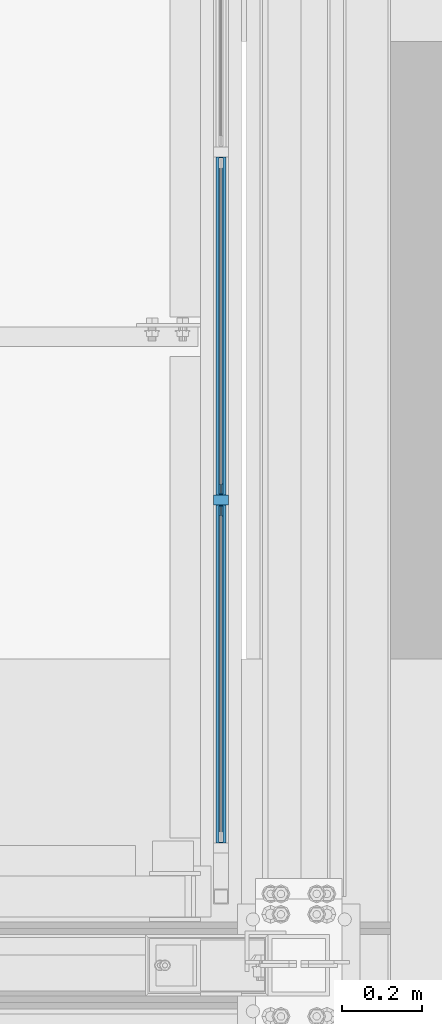
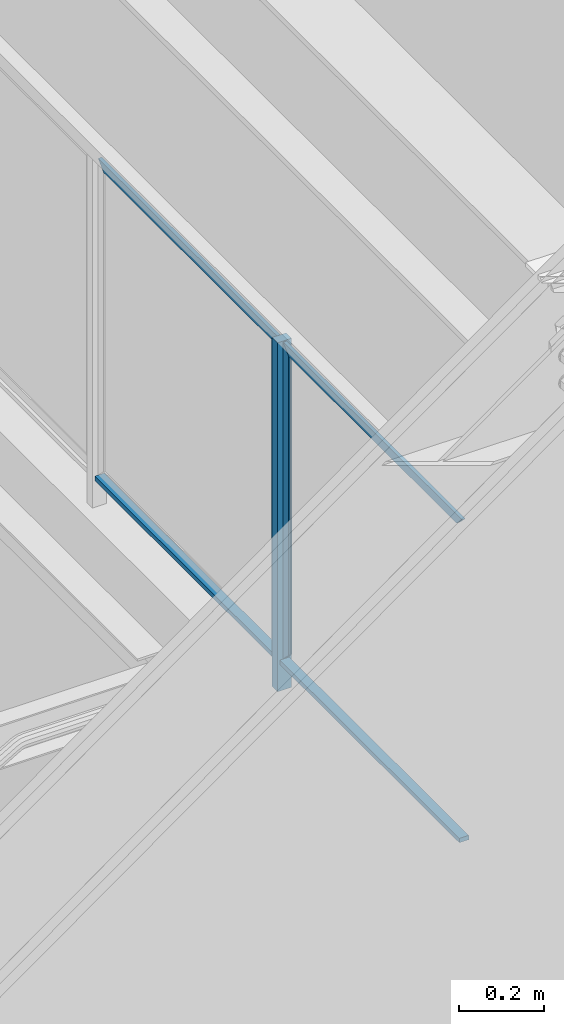
# One storey, part 923 of 1179: 4 beams, 3 members, 1 element without a shape of its own.
"""IFC2X3 building model written with IfcOpenShell, lengths in millimetres."""

from ifc_helpers import new_model, si_unit, frame, origin_with_axes, place, context, subcontext, project, spatial, faceted_brep, material, type_object, element, aggregate, save


model = new_model("IFC2X3")

# Units and contexts
model_context = context("Model", 3, precision=1e-05, world=origin_with_axes())
body_context = subcontext(model_context, "Body", "Model", "MODEL_VIEW")
ifc_project = project(units=[si_unit("LENGTHUNIT", "METRE", prefix="MILLI"), si_unit("AREAUNIT", "SQUARE_METRE"), si_unit("VOLUMEUNIT", "CUBIC_METRE"), si_unit("MASSUNIT", "GRAM", prefix="KILO"), si_unit("TIMEUNIT", "SECOND"), si_unit("PLANEANGLEUNIT", "RADIAN"), si_unit("SOLIDANGLEUNIT", "STERADIAN"), si_unit("THERMODYNAMICTEMPERATUREUNIT", "DEGREE_CELSIUS"), si_unit("LUMINOUSINTENSITYUNIT", "LUMEN")], contexts=[model_context])

# Site, building, storey
site_placement = place(None, origin_with_axes())
site = spatial("IfcSite", under=ifc_project, at=site_placement, CompositionType="ELEMENT")
building_placement = place(site_placement, origin_with_axes())
building = spatial("IfcBuilding", under=site, at=building_placement, Name="Undefined", CompositionType="ELEMENT")
storey_placement = place(building_placement, origin_with_axes())
storey = spatial("IfcBuildingStorey", under=building, at=storey_placement, Name="Undefined", CompositionType="ELEMENT", Elevation=0.0)

# Assembly, members, beams
assembly_placement = place(storey_placement, origin_with_axes())
assembly = element("IfcElementAssembly", 1, at=assembly_placement, inside=storey, Name="GUARDRAIL", AssemblyPlace="NOTDEFINED", PredefinedType="RIGID_FRAME")
ifc_material_1 = material(Name="STEEL/A36")
member_type_1 = type_object("IfcMemberType", PredefinedType="NOTDEFINED")
member_1_placement = place(assembly_placement, frame((24114.1250004143, 39143.5166666676, 6242.04999951704), z_axis=(-1.0, 0.0, 0.0), x_axis=(0.0, 0.0, 1.0)))
member_1 = element("IfcMember", 2, at=member_1_placement, type_object=member_type_1, material=ifc_material_1, Name="POST", context=body_context, shape_type="Brep", body=[
    faceted_brep([(0.0, 12.7000000000007, -19.0500000000029), (0.0, 12.7000000000007, 19.0500000000029), (996.950000401505, 12.6999999999971, 19.0499999999993), (996.950000401505, 12.6999999999971, -19.0499999999993), (0.0, -12.7000000000007, 19.0500000000029), (996.950000401505, -12.6999999999971, 19.0499999999993), (0.0, -12.7000000000007, -19.0500000000029), (996.950000401505, -12.6999999999971, -19.0499999999993)], [[[0, 1, 2, 3]], [[1, 4, 5, 2]], [[4, 6, 7, 5]], [[6, 0, 3, 7]], [[5, 7, 3, 2]], [[6, 4, 1, 0]]]),
])
ifc_material_2 = material(Name="STEEL/BUY-OUT")
beam_type = type_object("IfcBeamType", PredefinedType="NOTDEFINED")
beam_1_placement = place(assembly_placement, frame((24110.9500703529, 39183.3359575509, 6784.97499945388), z_axis=(0.0, 0.0, 1.0), x_axis=(0.0, -1.0, 0.0)))
beam_1 = element("IfcBeam", 3, at=beam_1_placement, type_object=beam_type, material=ifc_material_2, Name="U-EDGE", context=body_context, shape_type="Brep", body=[
    faceted_brep([(0.0, 1.58750000000146, -427.037571475466), (22.2249999999985, 1.58750000000146, -449.262071101228), (22.2249999999985, 4.76249999999709, -449.262071101228), (0.0, 4.76249999999709, -427.037571475466), (0.0, 7.9375, -427.037571475466), (25.4000000000015, 7.9375, -452.4375), (25.4000000000015, -1.58750000000146, -452.4375), (0.0, -1.58750000000146, -427.037571475466), (25.4000000000015, -1.58750000000146, 452.4375), (0.0, -1.58750000000146, 427.037500076054), (0.0, 1.58750000000146, 427.037500076054), (22.2249999999985, 1.58750000000146, 449.262500000033), (22.2249999999985, 4.76249999999709, 449.262500000033), (0.0, 4.76249999999709, 427.037500000033), (0.0, 7.9375, 427.037500000033), (25.4000000000015, 7.9375, 452.4375)], [[[0, 1, 2, 3, 4, 5, 6, 7]], [[7, 6, 8, 9]], [[0, 7, 9, 10]], [[1, 0, 10, 11]], [[2, 1, 11, 12]], [[3, 2, 12, 13]], [[4, 3, 13, 14]], [[5, 4, 14, 15]], [[6, 5, 15, 8]], [[14, 13, 12, 11, 10, 9, 8, 15]]]),
])
beam_2_placement = place(assembly_placement, frame((24110.9502052178, 39576.2424575509, 7212.01249945388), z_axis=(0.0, 1.0, 0.0), x_axis=(0.0, 0.0, 1.0)))
beam_2 = element("IfcBeam", 4, at=beam_2_placement, type_object=beam_type, material=ifc_material_2, Name="U-EDGE", context=body_context, shape_type="Brep", body=[
    faceted_brep([(0.0, 1.58750000000146, -392.906500000216), (22.2249999999785, 1.58750000000146, -415.131500000192), (22.2249999999603, 4.76236513509502, -415.131500000178), (-5.54791768081486e-11, 4.76236513509502, -392.906500000165), (-5.54791768081486e-11, 7.93736513509793, -392.906500000165), (25.3999999999414, 7.93736513509793, -418.306499999999), (25.3999999999969, -1.58750000000146, -418.306499999999), (0.0, -1.58750000000146, -392.906500000216), (25.3999999999969, -1.58750000000146, 418.306499999999), (0.0, -1.58750000000146, 392.90650078046), (0.0, 1.58750000000146, 392.90650078046), (22.2249999999785, 1.58750000000146, 415.131500780415), (22.2249999999603, 4.76236513509502, 415.131500780393), (-5.54791768081486e-11, 4.76236513509502, 392.90650078038), (-5.54791768081486e-11, 7.93736513509793, 392.90650078038), (25.3999999999414, 7.93736513509793, 418.306499999999)], [[[0, 1, 2, 3, 4, 5, 6, 7]], [[7, 6, 8, 9]], [[0, 7, 9, 10]], [[1, 0, 10, 11]], [[2, 1, 11, 12]], [[3, 2, 12, 13]], [[4, 3, 13, 14]], [[5, 4, 14, 15]], [[6, 5, 15, 8]], [[14, 13, 12, 11, 10, 9, 8, 15]]]),
])
beam_3_placement = place(assembly_placement, frame((24110.9500703529, 39103.4322916676, 6784.97499993605), z_axis=(0.0, 0.0, 1.0), x_axis=(0.0, 1.0, 0.0)))
beam_3 = element("IfcBeam", 5, at=beam_3_placement, type_object=beam_type, material=ifc_material_2, Name="U-EDGE", context=body_context, shape_type="Brep", body=[
    faceted_brep([(2.91038304567337e-11, -4.76249999999709, -427.037499923914), (22.2250000000131, -4.76249999999709, -449.2624999239), (22.2250000000131, -1.58750000000146, -449.2624999239), (0.0, -1.58750000000146, -427.037499923886), (0.0, 1.58750000000146, -427.037499923886), (25.4000000439901, 1.58750000000146, -452.437500000357), (25.4000000476099, -7.93749999539432, -452.437500000422), (2.91038304567337e-11, -7.9375, -427.037499923914), (25.4000000000647, -7.9375, 452.4375), (1.29148247651756e-10, -7.9375, 427.037500076181), (1.29148247651756e-10, -4.76249999999709, 427.037500076181), (22.2250000000645, -4.76249999999709, 449.262500076118), (22.2250000000645, -1.58750000000146, 449.262500076118), (0.0, -1.58750000000146, 427.037500076054), (0.0, 1.58750000000146, 427.037500076054), (25.4000000000647, 1.58750000000146, 452.4375)], [[[0, 1, 2, 3, 4, 5, 6, 7]], [[8, 9, 7, 6]], [[9, 10, 0, 7]], [[10, 11, 1, 0]], [[11, 12, 2, 1]], [[12, 13, 3, 2]], [[13, 14, 4, 3]], [[14, 15, 5, 4]], [[15, 8, 6, 5]], [[14, 13, 12, 11, 10, 9, 8, 15]]]),
])
beam_4_placement = place(assembly_placement, frame((24110.9502052178, 38710.5257908844, 7212.01249993611), z_axis=(0.0, 1.0, 0.0), x_axis=(0.0, 0.0, 1.0)))
beam_4 = element("IfcBeam", 6, at=beam_4_placement, type_object=beam_type, material=ifc_material_2, Name="U-EDGE", context=body_context, shape_type="Brep", body=[
    faceted_brep([(0.0, 1.58750000000146, -392.906500000216), (22.2249999999785, 1.58750000000146, -415.131500000192), (22.2249999999603, 4.76236513509502, -415.131500000178), (-5.54791768081486e-11, 4.76236513509502, -392.906500000165), (-5.54791768081486e-11, 7.93736513509793, -392.906500000165), (25.3999999999414, 7.93736513509793, -418.306499999999), (25.3999999999969, -1.58750000000146, -418.306499999999), (0.0, -1.58750000000146, -392.906500000216), (25.3999999999969, -1.58750000000146, 418.306499999999), (0.0, -1.58750000000146, 392.90650078046), (0.0, 1.58750000000146, 392.90650078046), (22.2249999999785, 1.58750000000146, 415.131500780415), (22.2249999999603, 4.76236513509502, 415.131500780393), (-5.54791768081486e-11, 4.76236513509502, 392.90650078038), (-5.54791768081486e-11, 7.93736513509793, 392.90650078038), (25.3999999999414, 7.93736513509793, 418.306499999999)], [[[0, 1, 2, 3, 4, 5, 6, 7]], [[7, 6, 8, 9]], [[0, 7, 9, 10]], [[1, 0, 10, 11]], [[2, 1, 11, 12]], [[3, 2, 12, 13]], [[4, 3, 13, 14]], [[5, 4, 14, 15]], [[6, 5, 15, 8]], [[14, 13, 12, 11, 10, 9, 8, 15]]]),
])
member_type_2 = type_object("IfcMemberType", PredefinedType="NOTDEFINED")
member_2_placement = place(assembly_placement, frame((24114.1250004143, 39143.5166666676, 6324.60000042314), z_axis=(1.0, 0.0, 0.0), x_axis=(0.0, 1.0, 0.0)))
member_2 = element("IfcMember", 7, at=member_2_placement, type_object=member_type_2, material=ifc_material_1, Name="BOTTOM_RAIL", context=body_context, shape_type="Brep", body=[
    faceted_brep([(12.6999999999971, 6.35000000000036, -12.7000000000007), (12.6999999999971, 6.35000000000036, 12.7000000000007), (853.01666666659, 6.35000000000036, 12.7000000000007), (853.01666666659, 6.35000000000036, -12.7000000000007), (12.6999999999971, -6.35000000000036, 12.7000000000007), (853.01666666659, -6.35000000000036, 12.7000000000007), (12.6999999999971, -6.35000000000036, -12.7000000000007), (853.01666666659, -6.35000000000036, -12.7000000000007)], [[[0, 1, 2, 3]], [[1, 4, 5, 2]], [[4, 6, 7, 5]], [[6, 0, 3, 7]], [[5, 7, 3, 2]], [[6, 4, 1, 0]]]),
])
member_3_placement = place(assembly_placement, frame((24114.1250004143, 38277.800000001, 6324.60000042314), z_axis=(1.0, 0.0, 0.0), x_axis=(0.0, 1.0, 0.0)))
member_3 = element("IfcMember", 8, at=member_3_placement, type_object=member_type_2, material=ifc_material_1, Name="BOTTOM_RAIL", context=body_context, shape_type="Brep", body=[
    faceted_brep([(12.6999999999971, 6.35000000000036, -12.7000000000007), (12.6999999999971, 6.35000000000036, 12.7000000000007), (853.01666666659, 6.35000000000036, 12.7000000000007), (853.01666666659, 6.35000000000036, -12.7000000000007), (12.6999999999971, -6.35000000000036, 12.7000000000007), (853.01666666659, -6.35000000000036, 12.7000000000007), (12.6999999999971, -6.35000000000036, -12.7000000000007), (853.01666666659, -6.35000000000036, -12.7000000000007)], [[[0, 1, 2, 3]], [[1, 4, 5, 2]], [[4, 6, 7, 5]], [[6, 0, 3, 7]], [[5, 7, 3, 2]], [[6, 4, 1, 0]]]),
])
aggregate(assembly, [beam_1, beam_2, member_2, beam_3, beam_4, member_3, member_1])

save(model, "model.ifc")
